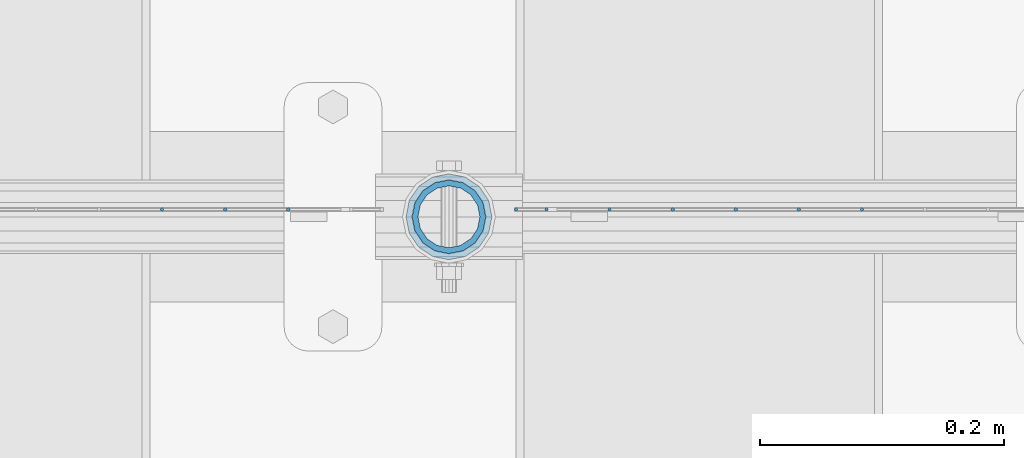
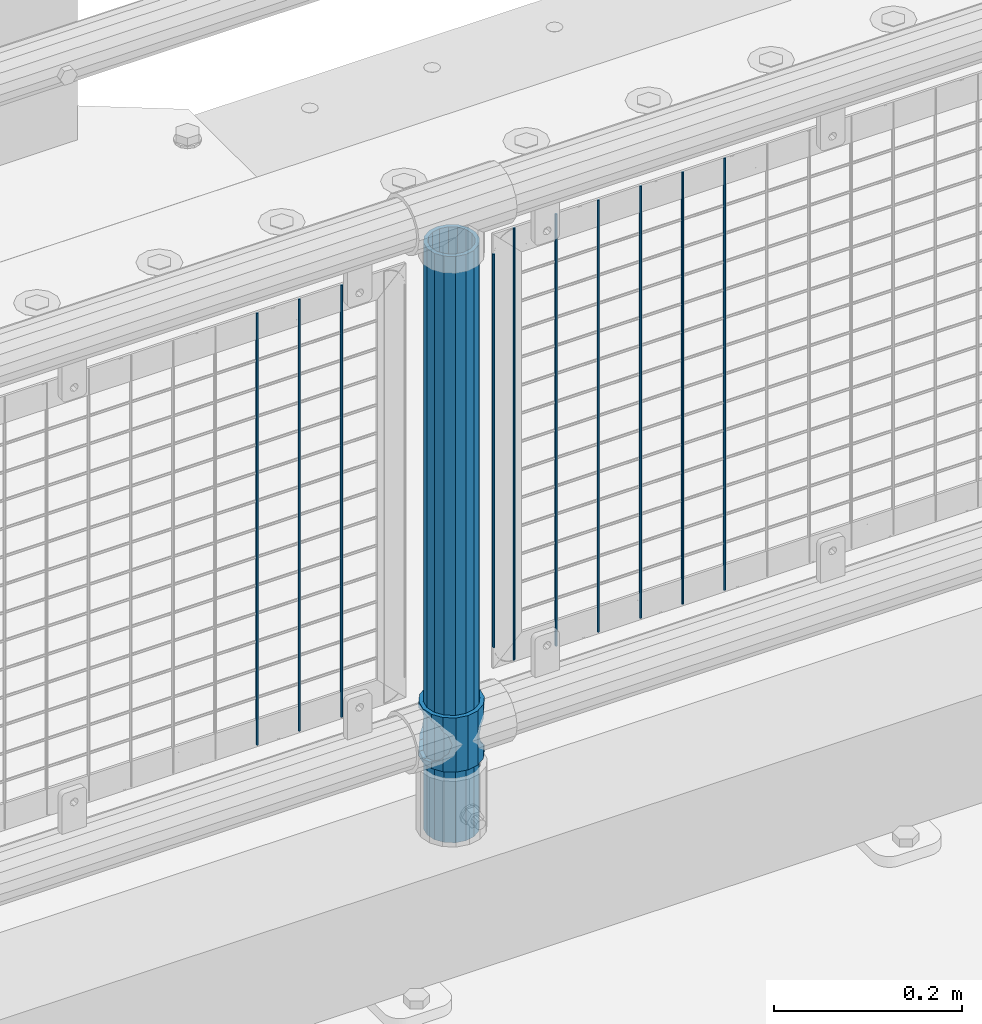
# One storey, part 77 of 240: 12 columns.
"""IFC2X3 building model written with IfcOpenShell, lengths in millimetres."""

from ifc_helpers import new_model, si_unit, frame, origin_with_axes, place, context, subcontext, project, spatial, faceted_brep, material, type_object, element, save


model = new_model("IFC2X3")

# Units and contexts
model_context = context("Model", 3, precision=1e-05, world=origin_with_axes())
body_context = subcontext(model_context, "Body", "Model", "MODEL_VIEW")
ifc_project = project(units=[si_unit("LENGTHUNIT", "METRE", prefix="MILLI"), si_unit("AREAUNIT", "SQUARE_METRE"), si_unit("VOLUMEUNIT", "CUBIC_METRE"), si_unit("MASSUNIT", "GRAM", prefix="KILO"), si_unit("TIMEUNIT", "SECOND"), si_unit("PLANEANGLEUNIT", "RADIAN"), si_unit("SOLIDANGLEUNIT", "STERADIAN"), si_unit("THERMODYNAMICTEMPERATUREUNIT", "DEGREE_CELSIUS"), si_unit("LUMINOUSINTENSITYUNIT", "LUMEN")], contexts=[model_context])

# Site, building, storey
site_placement = place(None, origin_with_axes())
site = spatial("IfcSite", under=ifc_project, at=site_placement, CompositionType="ELEMENT")
building_placement = place(site_placement, origin_with_axes())
building = spatial("IfcBuilding", under=site, at=building_placement, Name="Standard", CompositionType="ELEMENT")
storey_placement = place(building_placement, origin_with_axes())
storey = spatial("IfcBuildingStorey", under=building, at=storey_placement, Name="Undefined", CompositionType="ELEMENT", Elevation=0.0)

# Columns
ifc_material_1 = material(Name="Misc_Undefined")
column_type_1 = type_object("IfcColumnType", PredefinedType="NOTDEFINED")
column_1_placement = place(storey_placement, frame((48045.0, 34664.5, 263.02), z_axis=(-1.0, 0.0, 0.0), x_axis=(0.0, 0.0, 1.0)))
element("IfcColumn", 1, at=column_1_placement, inside=storey, type_object=column_type_1, material=ifc_material_1, context=body_context, shape_type="Brep", body=[
    faceted_brep([(56.6106908090114, 21.4606908090136, -21.4606908090136), (56.6106908090114, 21.4606908090136, -27.1226768591077), (61.9623795176703, 13.4513226476338, -32.4743655677739), (63.1897438117172, 11.6144421722784, -32.8397438117172), (63.1897438117172, 11.6144421722784, -28.0397438117143), (46.7644421722801, 28.0397438117143, -11.6144421722784), (46.7644421722801, 28.0397438117143, -20.0882031229849), (51.5310424079941, 24.8548033587067, -24.8548033587067), (35.1500000000015, 30.35, 0.0), (35.1499999999996, 30.3499999999985, -16.6306603983685), (23.5355578277192, 28.0397438117143, -11.6144421722784), (23.5355578277192, 28.0397438117143, -20.0882031229849), (13.6893091909879, 21.4606908090136, -21.4606908090136), (13.6893091909879, 21.4606908090136, -27.1226768591077), (18.7689575919921, 24.8548033587067, -24.8548033587067), (7.11025618828211, 11.6144421722784, -28.0397438117143), (7.11025618828211, 11.6144421722784, -32.8397438117172), (8.33762048232893, 13.4513226476338, -32.4743655677739), (4.79999999999961, 0.0, -30.3499999999985), (4.79999999999961, 0.0, -35.1500000000015), (7.11025618828211, -11.6144421722784, -28.0397438117143), (7.11025618828211, -11.6144421722784, -32.8397438117245), (13.6893091909879, -21.4606908090136, -21.4606908090136), (13.6893091909879, -21.4606908090136, -27.1226768591223), (8.33762048232455, -13.4513226476338, -32.4743655677739), (23.5355578277191, -28.0397438117143, -11.6144421722784), (23.5355578277191, -28.0397438117143, -20.0882031229994), (18.7689575919987, -24.8548033587067, -24.8548033587067), (35.1500000000015, -30.35, 0.0), (35.1499999999996, -30.3499999999985, -16.6306603983758), (46.7644421722801, -28.0397438117143, -11.6144421722784), (46.7644421722801, -28.0397438117143, -20.0882031229994), (56.6106908090114, -21.4606908090136, -21.4606908090136), (56.6106908090114, -21.4606908090136, -27.1226768591223), (51.5310424080006, -24.8548033587067, -24.8548033587067), (63.1897438117172, -11.6144421722784, -28.0397438117143), (63.1897438117172, -11.6144421722784, -32.8397438117245), (61.9623795176703, -13.4513226476338, -32.4743655677739), (65.4999999999997, 0.0, -30.3499999999985), (65.4999999999997, 0.0, -35.1500000000015), (0.0, -28.0397438117143, -11.6144421722784), (0.0, -30.3499999999985, 0.0), (0.0, -21.4606908090136, -21.4606908090136), (0.0, -11.6144421722784, -28.0397438117143), (0.0, 0.0, -30.3499999999985), (0.0, 11.6144421722784, -28.0397438117143), (0.0, 21.4606908090136, -21.4606908090136), (0.0, 28.0397438117143, -11.6144421722784), (0.0, 30.3499999999985, 0.0), (0.0, 28.0397438117143, 11.6144421722784), (23.5355578277192, 28.0397438117143, 11.6144421722784), (0.0, 21.4606908090136, 21.4606908090136), (13.6893091909879, 21.4606908090136, 21.4606908090136), (0.0, 11.6144421722784, 28.0397438117143), (7.11025618828211, 11.6144421722784, 28.0397438117143), (0.0, 0.0, 30.3499999999985), (4.79999999999961, 0.0, 30.3499999999985), (0.0, -11.6144421722784, 28.0397438117143), (7.11025618828205, -11.6144421722784, 28.0397438117143), (0.0, -21.4606908090136, 21.4606908090136), (13.6893091909879, -21.4606908090136, 21.4606908090136), (0.0, -28.0397438117143, 11.6144421722784), (23.5355578277191, -28.0397438117143, 11.6144421722784), (0.0, -32.4743655677739, 13.4513226476338), (0.0, -35.1500000000015, 0.0), (70.2999999999993, -35.1500000000015, 0.0), (70.2999999999993, -32.4743655677739, 13.4513226476338), (0.0, 13.4513226476338, -32.4743655677739), (0.0, 24.8548033587067, -24.8548033587067), (0.0, 0.0, -35.1500000000015), (0.0, -13.4513226476338, -32.4743655677739), (0.0, -24.8548033587067, -24.8548033587067), (0.0, -24.8548033587067, 24.8548033587067), (0.0, -13.4513226476338, 32.4743655677739), (0.0, 0.0, 35.1500000000015), (0.0, 13.4513226476338, 32.4743655677739), (0.0, 24.8548033587067, 24.8548033587067), (0.0, 32.4743655677739, 13.4513226476338), (0.0, 35.1500000000015, 0.0), (0.0, 32.4743655677739, -13.4513226476338), (0.0, -32.4743655677739, -13.4513226476338), (70.2999999999993, 32.4743655677739, 13.4513226476338), (70.2999999999993, 35.1500000000015, 0.0), (70.2999999999993, 32.4743655677739, -13.4513226476338), (70.2999999999993, 24.8548033587067, -24.8548033587067), (70.2999999999993, 13.4513226476338, -32.4743655677739), (70.2999999999993, 0.0, -35.1500000000015), (70.2999999999993, -13.4513226476338, -32.4743655677739), (70.2999999999993, -24.8548033587067, -24.8548033587067), (70.2999999999993, -32.4743655677739, -13.4513226476338), (70.2999999999993, 28.0397438117143, 11.6144421722784), (70.2999999999993, 21.4606908090136, 21.4606908090136), (56.6106908090114, 21.4606908090136, 21.4606908090136), (46.7644421722801, 28.0397438117143, 11.6144421722784), (70.2999999999993, 11.6144421722784, 28.0397438117143), (63.1897438117172, 11.6144421722784, 28.0397438117143), (70.2999999999993, 0.0, 30.3499999999985), (65.4999999999997, 0.0, 30.3499999999985), (70.2999999999993, -11.6144421722784, 28.0397438117143), (63.1897438117172, -11.6144421722784, 28.0397438117143), (70.2999999999993, -21.4606908090136, 21.4606908090136), (56.6106908090114, -21.4606908090136, 21.4606908090136), (70.2999999999993, -28.0397438117143, 11.6144421722784), (46.7644421722801, -28.0397438117143, 11.6144421722784), (70.2999999999993, -11.6144421722784, -28.0397438117143), (70.2999999999993, 0.0, -30.3499999999985), (70.2999999999993, -21.4606908090136, -21.4606908090136), (70.2999999999993, -28.0397438117143, -11.6144421722784), (70.2999999999993, -30.3499999999985, 0.0), (70.2999999999993, 24.8548033587067, 24.8548033587067), (70.2999999999993, 13.4513226476338, 32.4743655677739), (70.2999999999993, 0.0, 35.1500000000015), (70.2999999999993, -13.4513226476338, 32.4743655677739), (70.2999999999993, -24.8548033587067, 24.8548033587067), (70.2999999999993, 30.3499999999985, 0.0), (70.2999999999993, 28.0397438117143, -11.6144421722784), (70.2999999999993, 21.4606908090136, -21.4606908090136), (70.2999999999993, 11.6144421722784, -28.0397438117143), (61.9623795176742, 13.4513226476338, 32.4743655677739), (51.5310424079941, 24.8548033587067, 24.8548033587067), (56.6106908090114, 21.4606908090136, 27.1226768591077), (65.4999999999997, 0.0, 35.1500000000015), (63.1897438117172, 11.6144421722784, 32.8397438117172), (63.1897438117172, -11.6144421722784, 32.8397438117172), (61.9623795176698, -13.4513226476338, 32.4743655677739), (56.6106908090114, -21.4606908090136, 27.1226768591005), (51.5310424080006, -24.8548033587067, 24.8548033587067), (18.7689575919987, -24.8548033587067, 24.8548033587067), (46.7644421722801, -28.0397438117143, 20.0882031229994), (35.1499999999996, -30.3499999999985, 16.6306603983758), (23.5355578277191, -28.0397438117143, 20.0882031229994), (8.33762048232506, -13.4513226476338, 32.4743655677739), (13.6893091909879, -21.4606908090136, 27.1226768591005), (4.79999999999961, 0.0, 35.1500000000015), (7.11025618828205, -11.6144421722784, 32.8397438117172), (7.11025618828211, 11.6144421722784, 32.8397438117172), (8.33762048232506, 13.4513226476338, 32.4743655677739), (13.6893091909879, 21.4606908090136, 27.1226768591077), (18.7689575919856, 24.8548033587067, 24.8548033587067), (23.5355578277192, 28.0397438117143, 20.0882031229994), (35.1499999999996, 30.3499999999985, 16.6306603983758), (46.7644421722801, 28.0397438117143, 20.0882031229994)], [[[0, 1, 2, 3, 4]], [[5, 6, 7, 1, 0]], [[8, 9, 6, 5]], [[10, 11, 9, 8]], [[12, 13, 14, 11, 10]], [[15, 16, 17, 13, 12]], [[18, 19, 16, 15]], [[20, 21, 19, 18]], [[22, 23, 24, 21, 20]], [[25, 26, 27, 23, 22]], [[28, 29, 26, 25]], [[30, 31, 29, 28]], [[32, 33, 34, 31, 30]], [[35, 36, 37, 33, 32]], [[38, 39, 36, 35]], [[4, 3, 39, 38]], [[40, 41, 28, 25]], [[42, 40, 25, 22]], [[43, 42, 22, 20]], [[44, 43, 20, 18]], [[45, 44, 18, 15]], [[46, 45, 15, 12]], [[47, 46, 12, 10]], [[48, 47, 10, 8]], [[49, 48, 8, 50]], [[51, 49, 50, 52]], [[53, 51, 52, 54]], [[55, 53, 54, 56]], [[57, 55, 56, 58]], [[59, 57, 58, 60]], [[61, 59, 60, 62]], [[41, 61, 62, 28]], [[63, 64, 65, 66]], [[17, 67, 68, 14, 13]], [[19, 69, 67, 17, 16]], [[70, 69, 19, 21, 24]], [[71, 70, 24, 23, 27]], [[63, 72, 73, 74, 75, 76, 77, 78, 79, 68, 67, 69, 70, 71, 80, 64], [40, 42, 43, 44, 45, 46, 47, 48, 49, 51, 53, 55, 57, 59, 61, 41]], [[78, 77, 81, 82]], [[79, 78, 82, 83]], [[14, 68, 79, 83, 84, 7, 6, 9, 11]], [[84, 85, 2, 1, 7]], [[85, 86, 39, 3, 2]], [[37, 87, 88, 34, 33]], [[39, 86, 87, 37, 36]], [[34, 88, 89, 80, 71, 27, 26, 29, 31]], [[64, 80, 89, 65]], [[90, 91, 92, 93]], [[91, 94, 95, 92]], [[94, 96, 97, 95]], [[96, 98, 99, 97]], [[98, 100, 101, 99]], [[100, 102, 103, 101]], [[104, 105, 38, 35]], [[106, 104, 35, 32]], [[107, 106, 32, 30]], [[108, 107, 30, 28]], [[102, 108, 28, 103]], [[88, 87, 86, 85, 84, 83, 82, 81, 109, 110, 111, 112, 113, 66, 65, 89], [100, 98, 96, 94, 91, 90, 114, 115, 116, 117, 105, 104, 106, 107, 108, 102]], [[118, 110, 109, 119, 120]], [[121, 111, 110, 118, 122]], [[112, 111, 121, 123, 124]], [[113, 112, 124, 125, 126]], [[127, 72, 63, 66, 113, 126, 128, 129, 130]], [[131, 73, 72, 127, 132]], [[133, 74, 73, 131, 134]], [[75, 74, 133, 135, 136]], [[76, 75, 136, 137, 138]], [[119, 109, 81, 77, 76, 138, 139, 140, 141]], [[92, 120, 119, 141, 93]], [[95, 122, 118, 120, 92]], [[97, 121, 122, 95]], [[99, 123, 121, 97]], [[101, 125, 124, 123, 99]], [[103, 128, 126, 125, 101]], [[28, 129, 128, 103]], [[62, 130, 129, 28]], [[60, 132, 127, 130, 62]], [[58, 134, 131, 132, 60]], [[56, 133, 134, 58]], [[54, 135, 133, 56]], [[52, 137, 136, 135, 54]], [[50, 139, 138, 137, 52]], [[8, 140, 139, 50]], [[93, 141, 140, 8]], [[114, 90, 93, 8]], [[115, 114, 8, 5]], [[116, 115, 5, 0]], [[117, 116, 0, 4]], [[105, 117, 4, 38]]]),
])
ifc_material_2 = material()
column_type_2 = type_object("IfcColumnType", PredefinedType="NOTDEFINED")
column_2_placement = place(storey_placement, frame((48045.0, 34664.5, 168.02), z_axis=(-1.0, 0.0, 0.0), x_axis=(0.0, 0.0, 1.0)))
element("IfcColumn", 2, at=column_2_placement, inside=storey, type_object=column_type_2, material=ifc_material_2, context=body_context, shape_type="Brep", body=[
    faceted_brep([(0.0, -25.3499999999985, 0.0), (0.0, -23.4203461491634, 9.70102501045767), (760.0, -23.4203461491634, 9.70102501045767), (760.0, -25.3499999999985, 0.0), (0.0, -17.9251569030821, 17.9251569030821), (760.0, -17.9251569030821, 17.9251569030821), (0.0, -9.70102501045767, 23.4203461491634), (760.0, -9.70102501045767, 23.4203461491634), (0.0, 0.0, 25.3499999999985), (760.0, 0.0, 25.3499999999985), (0.0, 9.70102501045767, 23.4203461491634), (760.0, 9.70102501045767, 23.4203461491634), (0.0, 17.9251569030821, 17.9251569030821), (760.0, 17.9251569030821, 17.9251569030821), (0.0, 23.4203461491634, 9.70102501045767), (760.0, 23.4203461491634, 9.70102501045767), (0.0, 25.3499999999985, 0.0), (760.0, 25.3499999999985, 0.0), (0.0, 23.4203461491634, -9.70102501045767), (760.0, 23.4203461491634, -9.70102501045767), (0.0, 17.9251569030821, -17.9251569030821), (760.0, 17.9251569030821, -17.9251569030821), (0.0, 9.70102501045767, -23.4203461491634), (760.0, 9.70102501045767, -23.4203461491634), (0.0, 0.0, -25.3499999999985), (760.0, 0.0, -25.3499999999985), (0.0, -9.70102501045767, -23.4203461491634), (760.0, -9.70102501045767, -23.4203461491634), (0.0, -17.9251569030821, -17.9251569030821), (760.0, -17.9251569030821, -17.9251569030821), (0.0, -23.4203461491634, -9.70102501045767), (760.0, -23.4203461491634, -9.70102501045767), (0.0, -30.1500000000015, 0.0), (0.0, -27.8549679052157, -11.5379054858058), (760.0, -27.8549679052157, -11.5379054858058), (760.0, -30.1500000000015, 0.0), (0.0, -21.3192694527752, -21.3192694527752), (760.0, -21.3192694527752, -21.3192694527752), (0.0, -11.5379054858058, -27.8549679052157), (760.0, -11.5379054858058, -27.8549679052157), (0.0, 0.0, -30.1500000000015), (760.0, 0.0, -30.1500000000015), (0.0, 11.5379054858058, -27.8549679052157), (760.0, 11.5379054858058, -27.8549679052157), (0.0, 21.3192694527752, -21.3192694527752), (760.0, 21.3192694527752, -21.3192694527752), (0.0, 27.8549679052157, -11.5379054858058), (760.0, 27.8549679052157, -11.5379054858058), (0.0, 30.1500000000015, 0.0), (760.0, 30.1500000000015, 0.0), (0.0, 27.8549679052157, 11.5379054858058), (760.0, 27.8549679052157, 11.5379054858058), (0.0, 21.3192694527752, 21.3192694527752), (760.0, 21.3192694527752, 21.3192694527752), (0.0, 11.5379054858058, 27.8549679052157), (760.0, 11.5379054858058, 27.8549679052157), (0.0, 0.0, 30.1500000000015), (760.0, 0.0, 30.1500000000015), (0.0, -11.5379054858058, 27.8549679052157), (760.0, -11.5379054858058, 27.8549679052157), (0.0, -21.3192694527752, 21.3192694527752), (760.0, -21.3192694527752, 21.3192694527752), (0.0, -27.8549679052157, 11.5379054858058), (760.0, -27.8549679052157, 11.5379054858058)], [[[0, 1, 2, 3]], [[1, 4, 5, 2]], [[4, 6, 7, 5]], [[6, 8, 9, 7]], [[8, 10, 11, 9]], [[10, 12, 13, 11]], [[12, 14, 15, 13]], [[14, 16, 17, 15]], [[16, 18, 19, 17]], [[18, 20, 21, 19]], [[20, 22, 23, 21]], [[22, 24, 25, 23]], [[24, 26, 27, 25]], [[26, 28, 29, 27]], [[28, 30, 31, 29]], [[30, 0, 3, 31]], [[32, 33, 34, 35]], [[33, 36, 37, 34]], [[36, 38, 39, 37]], [[38, 40, 41, 39]], [[40, 42, 43, 41]], [[42, 44, 45, 43]], [[44, 46, 47, 45]], [[46, 48, 49, 47]], [[48, 50, 51, 49]], [[50, 52, 53, 51]], [[52, 54, 55, 53]], [[54, 56, 57, 55]], [[56, 58, 59, 57]], [[58, 60, 61, 59]], [[60, 62, 63, 61]], [[62, 32, 35, 63]], [[37, 39, 41, 43, 45, 47, 49, 51, 53, 55, 57, 59, 61, 63, 35, 34], [5, 7, 9, 11, 13, 15, 17, 19, 21, 23, 25, 27, 29, 31, 3, 2]], [[62, 60, 58, 56, 54, 52, 50, 48, 46, 44, 42, 40, 38, 36, 33, 32], [30, 28, 26, 24, 22, 20, 18, 16, 14, 12, 10, 8, 6, 4, 1, 0]]]),
])
column_type_3 = type_object("IfcColumnType", Name="D3", PredefinedType="NOTDEFINED")
for number, where, z_axis, x_axis in (
    (3, (48383.275, 34670.5, 353.02), (-1.0, 0.0, 0.0), (0.0, 0.0, 1.0)),
    (4, (48331.62, 34670.5, 353.02), (-1.0, 0.0, 0.0), (0.0, 0.0, 1.0)),
    (5, (48279.965, 34670.5, 353.02), (-1.0, 0.0, 0.0), (0.0, 0.0, 1.0)),
    (6, (48228.31, 34670.5, 353.02), (-1.0, 0.0, 0.0), (0.0, 0.0, 1.0)),
    (7, (48176.655, 34670.5, 353.02), (-1.0, 0.0, 0.0), (0.0, 0.0, 1.0)),
):
    element("IfcColumn", number, at=place(storey_placement, frame(where, z_axis=z_axis, x_axis=x_axis)), inside=storey, type_object=column_type_3, material=ifc_material_1, ObjectType="D3", context=body_context, shape_type="Brep", body=[
        faceted_brep([(-7.27595761418343e-12, -1.49999999999272, 0.0), (-7.27595761418343e-12, -0.749999999992724, -1.29903810567669), (560.0, -0.75, -1.29903810567339), (560.0, -1.5, 0.0), (0.0, 0.750000000007276, -1.29903810567669), (560.0, 0.75, -1.29903810567339), (0.0, 1.50000000000728, 0.0), (560.0, 1.5, 0.0), (0.0, 0.750000000007276, 1.29903810567669), (560.0, 0.75, 1.29903810567339), (-7.27595761418343e-12, -0.749999999992724, 1.29903810567669), (560.0, -0.75, 1.29903810567339)], [[[0, 1, 2, 3]], [[1, 4, 5, 2]], [[4, 6, 7, 5]], [[6, 8, 9, 7]], [[8, 10, 11, 9]], [[10, 0, 3, 11]], [[5, 7, 9, 11, 3, 2]], [[10, 8, 6, 4, 1, 0]]]),
    ])
column_3_placement = place(storey_placement, frame((48100.0, 34670.5, 378.02), z_axis=(-1.0, 0.0, 0.0), x_axis=(0.0, 0.0, 1.0)))
element("IfcColumn", 8, at=column_3_placement, inside=storey, type_object=column_type_3, material=ifc_material_1, ObjectType="D3", context=body_context, shape_type="Brep", body=[
    faceted_brep([(-7.27595761418343e-12, -1.49999999999272, 0.0), (-7.27595761418343e-12, -0.749999999992724, -1.29903810567669), (510.0, -0.75, -1.29903810567339), (510.0, -1.5, 0.0), (0.0, 0.750000000007276, -1.29903810567669), (510.0, 0.75, -1.29903810567339), (0.0, 1.50000000000728, 0.0), (510.0, 1.5, 0.0), (0.0, 0.750000000007276, 1.29903810567669), (510.0, 0.75, 1.29903810567339), (-7.27595761418343e-12, -0.749999999992724, 1.29903810567669), (510.0, -0.75, 1.29903810567339)], [[[0, 1, 2, 3]], [[1, 4, 5, 2]], [[4, 6, 7, 5]], [[6, 8, 9, 7]], [[8, 10, 11, 9]], [[10, 0, 3, 11]], [[5, 7, 9, 11, 3, 2]], [[10, 8, 6, 4, 1, 0]]]),
])
for number, where, z_axis, x_axis in (
    (9, (48125.0, 34670.5, 353.02), (-1.0, 0.0, 0.0), (0.0, 0.0, 1.0)),
    (10, (47913.34, 34670.5, 353.02), (-1.0, 0.0, 0.0), (0.0, 0.0, 1.0)),
    (11, (47861.685, 34670.5, 353.02), (-1.0, 0.0, 0.0), (0.0, 0.0, 1.0)),
    (12, (47810.03, 34670.5, 353.02), (-1.0, 0.0, 0.0), (0.0, 0.0, 1.0)),
):
    element("IfcColumn", number, at=place(storey_placement, frame(where, z_axis=z_axis, x_axis=x_axis)), inside=storey, type_object=column_type_3, material=ifc_material_1, ObjectType="D3", context=body_context, shape_type="Brep", body=[
        faceted_brep([(-7.27595761418343e-12, -1.49999999999272, 0.0), (-7.27595761418343e-12, -0.749999999992724, -1.29903810567669), (560.0, -0.75, -1.29903810567339), (560.0, -1.5, 0.0), (0.0, 0.750000000007276, -1.29903810567669), (560.0, 0.75, -1.29903810567339), (0.0, 1.50000000000728, 0.0), (560.0, 1.5, 0.0), (0.0, 0.750000000007276, 1.29903810567669), (560.0, 0.75, 1.29903810567339), (-7.27595761418343e-12, -0.749999999992724, 1.29903810567669), (560.0, -0.75, 1.29903810567339)], [[[0, 1, 2, 3]], [[1, 4, 5, 2]], [[4, 6, 7, 5]], [[6, 8, 9, 7]], [[8, 10, 11, 9]], [[10, 0, 3, 11]], [[5, 7, 9, 11, 3, 2]], [[10, 8, 6, 4, 1, 0]]]),
    ])

save(model, "model.ifc")
